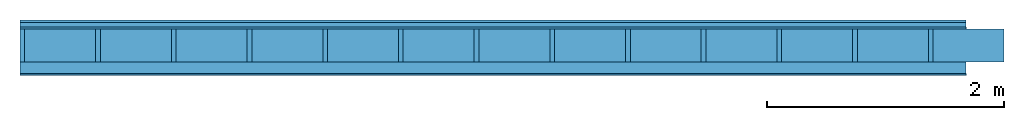
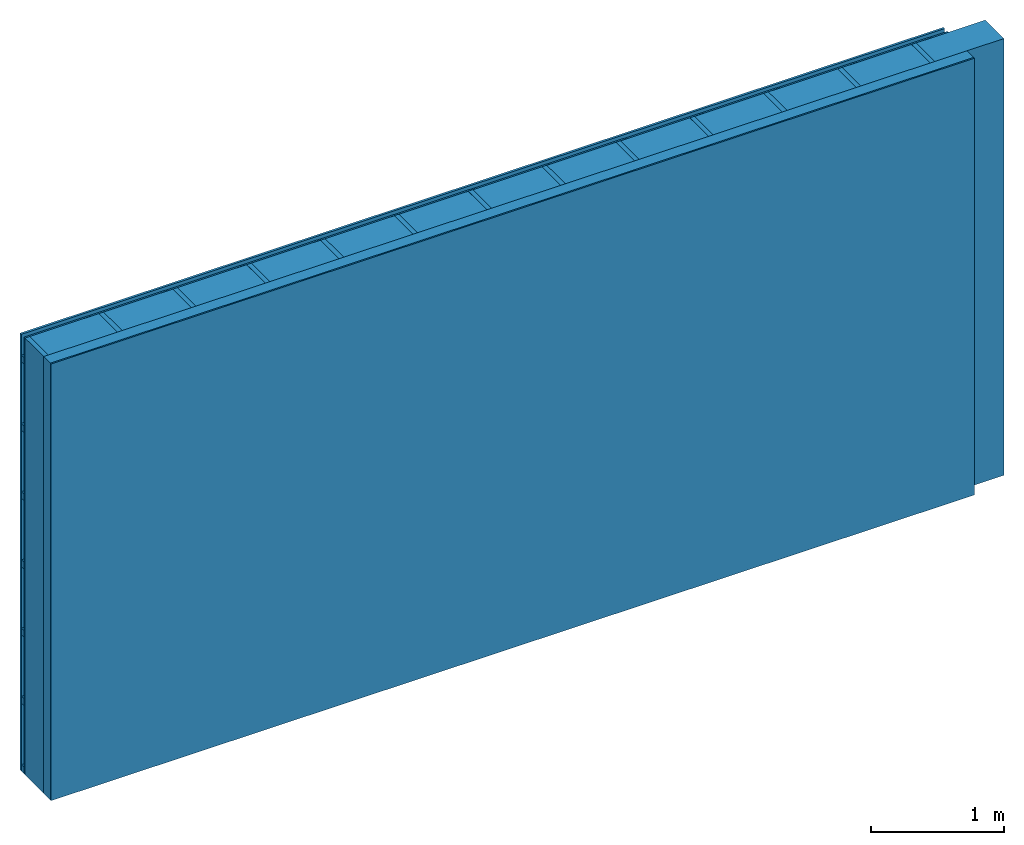
# One storey: 4 plates, 3 members, 1 element without a shape of its own.
"""IFC4 building model written with IfcOpenShell, lengths in metres."""

from ifc_helpers import new_model, si_unit, derived_unit, direction, frame, frame_2d, origin, origin_with_axes, place, context, project, spatial, rectangle, extrude, material, layer, layer_set, type_object, element, aggregate, save


model = new_model("IFC4")

# Units and contexts
plan_context = context("Plan", 3, precision=1e-05, world=origin(), true_north=direction((0.0, 1.0)))
model_context = context("Model", 3, precision=1e-05, world=origin(), true_north=direction((0.0, 1.0)))
ifc_project = project(units=[si_unit("LENGTHUNIT", "METRE"), derived_unit("SOUNDPRESSUREUNIT", [(si_unit("PRESSUREUNIT", "PASCAL", prefix="MICRO"), 0)]), si_unit("ENERGYUNIT", "JOULE", prefix="MEGA"), si_unit("MASSUNIT", "GRAM", prefix="KILO"), derived_unit("THERMALTRANSMITTANCEUNIT", [(si_unit("POWERUNIT", "WATT"), 1), (si_unit("AREAUNIT", "SQUARE_METRE"), -1), (si_unit("THERMODYNAMICTEMPERATUREUNIT", "KELVIN"), -1)]), derived_unit("AREADENSITYUNIT", [(si_unit("MASSUNIT", "GRAM", prefix="KILO"), 1), (si_unit("AREAUNIT", "SQUARE_METRE"), -1)]), derived_unit("USERDEFINED", [(si_unit("ENERGYUNIT", "JOULE", prefix="MEGA"), 1), (si_unit("AREAUNIT", "SQUARE_METRE"), -1)])], contexts=[plan_context, model_context])

# Site, building, storey
site = spatial("IfcSite", under=ifc_project)
building_placement = place(None, origin())
building = spatial("IfcBuilding", under=site, at=building_placement)
storey_placement = place(building_placement, origin())
storey = spatial("IfcBuildingStorey", under=building, at=storey_placement)

# Wall, members, plates
ifc_material_1 = material(Name="Wood cladding horizontal, closed")
ifc_layer_1 = layer(ifc_material_1, 0.02, Name="Cover 1st layer")
ifc_layer_2 = layer(None, 0.04, Name="Battens / profiles (ventilation)")
ifc_material_2 = material(Category="03.007")
ifc_layer_3 = layer(ifc_material_2, 0.015, Name="outside 1st layer")
ifc_material_3 = material(Name="of the art")
ifc_layer_4 = layer(ifc_material_3, 0.0, Name="Bond")
ifc_layer_5 = layer(None, 0.28, Name="Support")
ifc_layer_6 = layer(ifc_material_3, 0.0, Name="Bond")
ifc_material_4 = material(Name="Solid timber panel")
ifc_layer_7 = layer(ifc_material_4, 0.1, Name="1st layer")
ifc_material_5 = material(Name="Plasterboard type A", Category="03.008")
ifc_layer_8 = layer(ifc_material_5, 0.0125, Name="Covering 1st layer")
ifc_material_6 = material(Name="joints", Category="04.017")
ifc_layer_9 = layer(ifc_material_6, 0.0, Name="Surface")
ifc_layer_set = layer_set([ifc_layer_1, ifc_layer_2, ifc_layer_3, ifc_layer_4, ifc_layer_5, ifc_layer_6, ifc_layer_7, ifc_layer_8, ifc_layer_9])
wall_type = type_object("IfcWallType", Name="D0992", PredefinedType="NOTDEFINED", material=ifc_layer_set)
wall_placement = place(None, frame((0.0, 0.0, 0.0), z_axis=(0.0, -1.0, 0.0), x_axis=(1.0, 0.0, 0.0)))
wall = element("IfcWall", 1, at=wall_placement, inside=storey, type_object=wall_type, material=ifc_layer_set, Name="Wall #1")
ifc_material_7 = material()
member_1_placement = place(wall_placement, origin())
member_1 = element("IfcMember", 2, at=member_1_placement, material=ifc_material_7, Name="Battens / profiles (ventilation)", context=plan_context, shape_type="SweptSolid", body=[
    extrude(rectangle(XDim=0.06, YDim=0.04, at=frame_2d((0.03, 0.02), x_axis=(1.0, 0.0))), frame((0.0, 0.0, 0.02), z_axis=(1.0, 0.0, 0.0), x_axis=(0.0, 1.0, 0.0)), (0.0, 0.0, 1.0), 8.0),
    extrude(rectangle(XDim=0.06, YDim=0.04, at=frame_2d((0.03, 0.02), x_axis=(1.0, 0.0))), frame((0.0, 0.625, 0.02), z_axis=(1.0, 0.0, 0.0), x_axis=(0.0, 1.0, 0.0)), (0.0, 0.0, 1.0), 8.0),
    extrude(rectangle(XDim=0.06, YDim=0.04, at=frame_2d((0.03, 0.02), x_axis=(1.0, 0.0))), frame((0.0, 1.25, 0.02), z_axis=(1.0, 0.0, 0.0), x_axis=(0.0, 1.0, 0.0)), (0.0, 0.0, 1.0), 8.0),
    extrude(rectangle(XDim=0.06, YDim=0.04, at=frame_2d((0.03, 0.02), x_axis=(1.0, 0.0))), frame((0.0, 1.875, 0.02), z_axis=(1.0, 0.0, 0.0), x_axis=(0.0, 1.0, 0.0)), (0.0, 0.0, 1.0), 8.0),
    extrude(rectangle(XDim=0.06, YDim=0.04, at=frame_2d((0.03, 0.02), x_axis=(1.0, 0.0))), frame((0.0, 2.5, 0.02), z_axis=(1.0, 0.0, 0.0), x_axis=(0.0, 1.0, 0.0)), (0.0, 0.0, 1.0), 8.0),
    extrude(rectangle(XDim=0.06, YDim=0.04, at=frame_2d((0.03, 0.02), x_axis=(1.0, 0.0))), frame((0.0, 3.125, 0.02), z_axis=(1.0, 0.0, 0.0), x_axis=(0.0, 1.0, 0.0)), (0.0, 0.0, 1.0), 8.0),
    extrude(rectangle(XDim=0.06, YDim=0.04, at=frame_2d((0.03, 0.02), x_axis=(1.0, 0.0))), frame((0.0, 3.75, 0.02), z_axis=(1.0, 0.0, 0.0), x_axis=(0.0, 1.0, 0.0)), (0.0, 0.0, 1.0), 8.0),
])
ifc_material_8 = material()
member_2_placement = place(wall_placement, origin())
member_2 = element("IfcMember", 3, at=member_2_placement, material=ifc_material_8, Name="Support", context=plan_context, shape_type="SweptSolid", body=[
    extrude(rectangle(XDim=0.04, YDim=0.28, at=frame_2d((0.02, 0.14), x_axis=(1.0, 0.0))), frame((0.0, 4.0, 0.075), z_axis=(0.0, -1.0, 0.0), x_axis=(1.0, 0.0, 0.0)), (0.0, 0.0, 1.0), 4.0),
    extrude(rectangle(XDim=0.04, YDim=0.28, at=frame_2d((0.02, 0.14), x_axis=(1.0, 0.0))), frame((0.64, 4.0, 0.075), z_axis=(0.0, -1.0, 0.0), x_axis=(1.0, 0.0, 0.0)), (0.0, 0.0, 1.0), 4.0),
    extrude(rectangle(XDim=0.04, YDim=0.28, at=frame_2d((0.02, 0.14), x_axis=(1.0, 0.0))), frame((1.28, 4.0, 0.075), z_axis=(0.0, -1.0, 0.0), x_axis=(1.0, 0.0, 0.0)), (0.0, 0.0, 1.0), 4.0),
    extrude(rectangle(XDim=0.04, YDim=0.28, at=frame_2d((0.02, 0.14), x_axis=(1.0, 0.0))), frame((1.92, 4.0, 0.075), z_axis=(0.0, -1.0, 0.0), x_axis=(1.0, 0.0, 0.0)), (0.0, 0.0, 1.0), 4.0),
    extrude(rectangle(XDim=0.04, YDim=0.28, at=frame_2d((0.02, 0.14), x_axis=(1.0, 0.0))), frame((2.56, 4.0, 0.075), z_axis=(0.0, -1.0, 0.0), x_axis=(1.0, 0.0, 0.0)), (0.0, 0.0, 1.0), 4.0),
    extrude(rectangle(XDim=0.04, YDim=0.28, at=frame_2d((0.02, 0.14), x_axis=(1.0, 0.0))), frame((3.2, 4.0, 0.075), z_axis=(0.0, -1.0, 0.0), x_axis=(1.0, 0.0, 0.0)), (0.0, 0.0, 1.0), 4.0),
    extrude(rectangle(XDim=0.04, YDim=0.28, at=frame_2d((0.02, 0.14), x_axis=(1.0, 0.0))), frame((3.84, 4.0, 0.075), z_axis=(0.0, -1.0, 0.0), x_axis=(1.0, 0.0, 0.0)), (0.0, 0.0, 1.0), 4.0),
    extrude(rectangle(XDim=0.04, YDim=0.28, at=frame_2d((0.02, 0.14), x_axis=(1.0, 0.0))), frame((4.48, 4.0, 0.075), z_axis=(0.0, -1.0, 0.0), x_axis=(1.0, 0.0, 0.0)), (0.0, 0.0, 1.0), 4.0),
    extrude(rectangle(XDim=0.04, YDim=0.28, at=frame_2d((0.02, 0.14), x_axis=(1.0, 0.0))), frame((5.12, 4.0, 0.075), z_axis=(0.0, -1.0, 0.0), x_axis=(1.0, 0.0, 0.0)), (0.0, 0.0, 1.0), 4.0),
    extrude(rectangle(XDim=0.04, YDim=0.28, at=frame_2d((0.02, 0.14), x_axis=(1.0, 0.0))), frame((5.76, 4.0, 0.075), z_axis=(0.0, -1.0, 0.0), x_axis=(1.0, 0.0, 0.0)), (0.0, 0.0, 1.0), 4.0),
    extrude(rectangle(XDim=0.04, YDim=0.28, at=frame_2d((0.02, 0.14), x_axis=(1.0, 0.0))), frame((6.4, 4.0, 0.075), z_axis=(0.0, -1.0, 0.0), x_axis=(1.0, 0.0, 0.0)), (0.0, 0.0, 1.0), 4.0),
    extrude(rectangle(XDim=0.04, YDim=0.28, at=frame_2d((0.02, 0.14), x_axis=(1.0, 0.0))), frame((7.04, 4.0, 0.075), z_axis=(0.0, -1.0, 0.0), x_axis=(1.0, 0.0, 0.0)), (0.0, 0.0, 1.0), 4.0),
    extrude(rectangle(XDim=0.04, YDim=0.28, at=frame_2d((0.02, 0.14), x_axis=(1.0, 0.0))), frame((7.68, 4.0, 0.075), z_axis=(0.0, -1.0, 0.0), x_axis=(1.0, 0.0, 0.0)), (0.0, 0.0, 1.0), 4.0),
])
ifc_material_9 = material(Name="Mineral wool")
member_3_placement = place(wall_placement, origin())
member_3 = element("IfcMember", 4, at=member_3_placement, material=ifc_material_9, Name="Cavity", context=plan_context, shape_type="SweptSolid", body=[
    extrude(rectangle(XDim=0.6, YDim=0.28, at=frame_2d((0.3, 0.14), x_axis=(1.0, 0.0))), frame((0.04, 4.0, 0.075), z_axis=(0.0, -1.0, 0.0), x_axis=(1.0, 0.0, 0.0)), (0.0, 0.0, 1.0), 4.0),
    extrude(rectangle(XDim=0.6, YDim=0.28, at=frame_2d((0.3, 0.14), x_axis=(1.0, 0.0))), frame((0.68, 4.0, 0.075), z_axis=(0.0, -1.0, 0.0), x_axis=(1.0, 0.0, 0.0)), (0.0, 0.0, 1.0), 4.0),
    extrude(rectangle(XDim=0.6, YDim=0.28, at=frame_2d((0.3, 0.14), x_axis=(1.0, 0.0))), frame((1.32, 4.0, 0.075), z_axis=(0.0, -1.0, 0.0), x_axis=(1.0, 0.0, 0.0)), (0.0, 0.0, 1.0), 4.0),
    extrude(rectangle(XDim=0.6, YDim=0.28, at=frame_2d((0.3, 0.14), x_axis=(1.0, 0.0))), frame((1.96, 4.0, 0.075), z_axis=(0.0, -1.0, 0.0), x_axis=(1.0, 0.0, 0.0)), (0.0, 0.0, 1.0), 4.0),
    extrude(rectangle(XDim=0.6, YDim=0.28, at=frame_2d((0.3, 0.14), x_axis=(1.0, 0.0))), frame((2.6, 4.0, 0.075), z_axis=(0.0, -1.0, 0.0), x_axis=(1.0, 0.0, 0.0)), (0.0, 0.0, 1.0), 4.0),
    extrude(rectangle(XDim=0.6, YDim=0.28, at=frame_2d((0.3, 0.14), x_axis=(1.0, 0.0))), frame((3.24, 4.0, 0.075), z_axis=(0.0, -1.0, 0.0), x_axis=(1.0, 0.0, 0.0)), (0.0, 0.0, 1.0), 4.0),
    extrude(rectangle(XDim=0.6, YDim=0.28, at=frame_2d((0.3, 0.14), x_axis=(1.0, 0.0))), frame((3.88, 4.0, 0.075), z_axis=(0.0, -1.0, 0.0), x_axis=(1.0, 0.0, 0.0)), (0.0, 0.0, 1.0), 4.0),
    extrude(rectangle(XDim=0.6, YDim=0.28, at=frame_2d((0.3, 0.14), x_axis=(1.0, 0.0))), frame((4.52, 4.0, 0.075), z_axis=(0.0, -1.0, 0.0), x_axis=(1.0, 0.0, 0.0)), (0.0, 0.0, 1.0), 4.0),
    extrude(rectangle(XDim=0.6, YDim=0.28, at=frame_2d((0.3, 0.14), x_axis=(1.0, 0.0))), frame((5.16, 4.0, 0.075), z_axis=(0.0, -1.0, 0.0), x_axis=(1.0, 0.0, 0.0)), (0.0, 0.0, 1.0), 4.0),
    extrude(rectangle(XDim=0.6, YDim=0.28, at=frame_2d((0.3, 0.14), x_axis=(1.0, 0.0))), frame((5.8, 4.0, 0.075), z_axis=(0.0, -1.0, 0.0), x_axis=(1.0, 0.0, 0.0)), (0.0, 0.0, 1.0), 4.0),
    extrude(rectangle(XDim=0.6, YDim=0.28, at=frame_2d((0.3, 0.14), x_axis=(1.0, 0.0))), frame((6.44, 4.0, 0.075), z_axis=(0.0, -1.0, 0.0), x_axis=(1.0, 0.0, 0.0)), (0.0, 0.0, 1.0), 4.0),
    extrude(rectangle(XDim=0.6, YDim=0.28, at=frame_2d((0.3, 0.14), x_axis=(1.0, 0.0))), frame((7.08, 4.0, 0.075), z_axis=(0.0, -1.0, 0.0), x_axis=(1.0, 0.0, 0.0)), (0.0, 0.0, 1.0), 4.0),
    extrude(rectangle(XDim=0.6, YDim=0.28, at=frame_2d((0.3, 0.14), x_axis=(1.0, 0.0))), frame((7.72, 4.0, 0.075), z_axis=(0.0, -1.0, 0.0), x_axis=(1.0, 0.0, 0.0)), (0.0, 0.0, 1.0), 4.0),
])
plate_1_placement = place(wall_placement, origin())
plate_1 = element("IfcPlate", 5, at=plate_1_placement, material=ifc_material_1, Name="Cover 1st layer", context=plan_context, shape_type="SweptSolid", body=[
    extrude(rectangle(XDim=8.0, YDim=4.0, at=frame_2d((4.0, 2.0), x_axis=(1.0, 0.0))), origin_with_axes(), (0.0, 0.0, 1.0), 0.02),
])
plate_2_placement = place(wall_placement, origin())
plate_2 = element("IfcPlate", 6, at=plate_2_placement, material=ifc_material_2, Name="outside 1st layer", context=plan_context, shape_type="SweptSolid", body=[
    extrude(rectangle(XDim=8.0, YDim=4.0, at=frame_2d((4.0, 2.0), x_axis=(1.0, 0.0))), frame((0.0, 0.0, 0.06), z_axis=(0.0, 0.0, 1.0), x_axis=(1.0, 0.0, 0.0)), (0.0, 0.0, 1.0), 0.015),
])
plate_3_placement = place(wall_placement, origin())
plate_3 = element("IfcPlate", 7, at=plate_3_placement, material=ifc_material_4, Name="1st layer", context=plan_context, shape_type="SweptSolid", body=[
    extrude(rectangle(XDim=8.0, YDim=4.0, at=frame_2d((4.0, 2.0), x_axis=(1.0, 0.0))), frame((0.0, 0.0, 0.355), z_axis=(0.0, 0.0, 1.0), x_axis=(1.0, 0.0, 0.0)), (0.0, 0.0, 1.0), 0.1),
])
plate_4_placement = place(wall_placement, origin())
plate_4 = element("IfcPlate", 8, at=plate_4_placement, material=ifc_material_5, Name="Covering 1st layer", context=plan_context, shape_type="SweptSolid", body=[
    extrude(rectangle(XDim=8.0, YDim=4.0, at=frame_2d((4.0, 2.0), x_axis=(1.0, 0.0))), frame((0.0, 0.0, 0.455), z_axis=(0.0, 0.0, 1.0), x_axis=(1.0, 0.0, 0.0)), (0.0, 0.0, 1.0), 0.0125),
])
aggregate(wall, [plate_1, member_1, plate_2, member_2, member_3, plate_3, plate_4])

save(model, "model.ifc")
